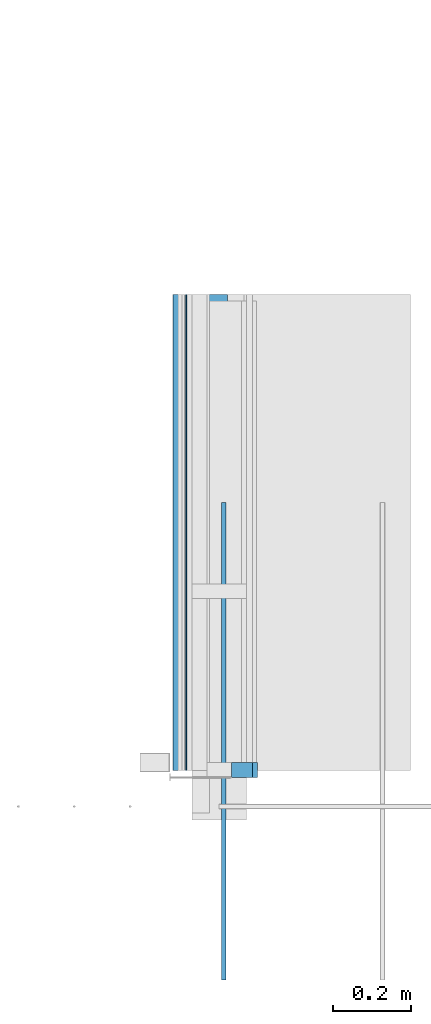
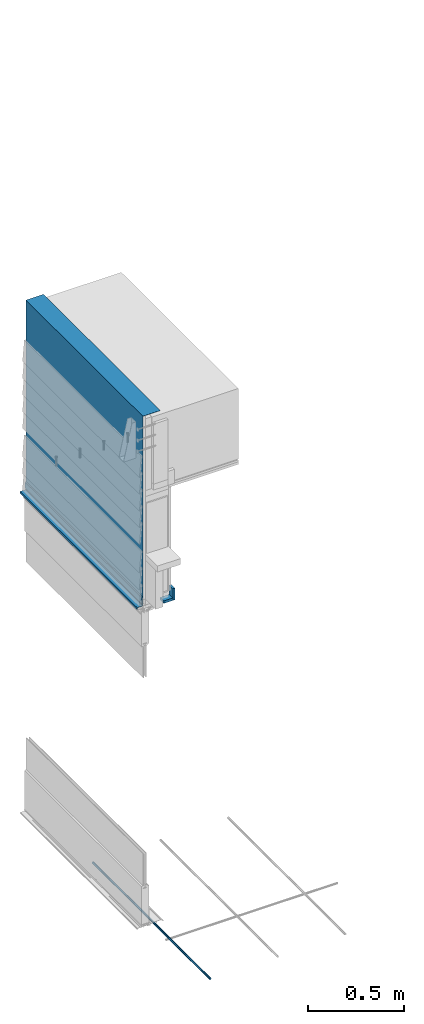
# One storey, part 3 of 44: 5 walls.
"""IFC4 building model written with IfcOpenShell, lengths in feet."""

import ifcopenshell
import ifcopenshell.guid

model = None  # the IFC model being written
_history = None  # IfcOwnerHistory: only IFC2X3 demands one
_inside = {}  # id of a spatial element -> (the spatial element, [elements in it])
_under = {}  # id of a project, library or spatial element -> (it, [spatial elements below it])
_declared = {}  # id of a project -> (the project, [libraries it declares])
_typed = {}  # id of a type object -> (the type object, [elements of that type])
_made_of = {}  # id of a material, layer set ... -> (it, [elements and type objects made of it])


def new_model(schema):
    """Start an empty IFC model of exactly this schema.

    Asked for "IFC4X3", IfcOpenShell would pick the latest addendum, in which some entities
    have other attributes; the version numbers below select the first issue.
    IFC2X3 requires an IfcOwnerHistory on every rooted entity: one is made here for all.
    """
    global model, _history
    if schema == "IFC4X3":
        model = ifcopenshell.file(schema_version=(4, 3, 0, 0))
    else:
        model = ifcopenshell.file(schema=schema)
    _inside.clear()
    _under.clear()
    _declared.clear()
    _typed.clear()
    _made_of.clear()
    _history = None
    if model.schema == "IFC2X3":
        org = make("IfcOrganization", Name="unknown")
        user = make(
            "IfcPersonAndOrganization",
            ThePerson=make("IfcPerson", FamilyName="unknown"),
            TheOrganization=org,
        )
        app = make(
            "IfcApplication",
            ApplicationDeveloper=org,
            Version="unknown",
            ApplicationFullName="unknown",
            ApplicationIdentifier="unknown",
        )
        _history = make(
            "IfcOwnerHistory",
            OwningUser=user,
            OwningApplication=app,
            ChangeAction="ADDED",
            CreationDate=0,
        )
    return model


def make(cls, **values):
    """One entity of the class cls with the attributes given. An attribute that is None is left unset."""
    return model.create_entity(
        cls, **{name: value for name, value in values.items() if value is not None}
    )


def entity(cls, *values):
    """Any entity or typed value of the class cls, its attributes in the order of the schema. None: left unset."""
    e = model.create_entity(cls)
    for i, value in enumerate(values):
        if value is not None:
            e[i] = value
    return e


def rooted(cls, **values):
    """An entity with a GlobalId (a new one), such as an element, a storey or a relation."""
    return make(cls, GlobalId=ifcopenshell.guid.new(), OwnerHistory=_history, **values)


def si_unit(unit_type, name, prefix=None):
    """IfcSIUnit, for example si_unit("LENGTHUNIT", "METRE", prefix="MILLI")."""
    return make("IfcSIUnit", UnitType=unit_type, Prefix=prefix, Name=name)


def converted_unit(unit_type, name, factor, base, dimensions=None, offset=None):
    """IfcConversionBasedUnit, such as the inch: factor (a typed value) times the base unit."""
    return make(
        "IfcConversionBasedUnit"
        if offset is None
        else "IfcConversionBasedUnitWithOffset",
        ConversionOffset=offset,
        Dimensions=None
        if dimensions is None
        else entity("IfcDimensionalExponents", *dimensions),
        UnitType=unit_type,
        Name=name,
        ConversionFactor=make(
            "IfcMeasureWithUnit", ValueComponent=factor, UnitComponent=base
        ),
    )


def derived_unit(unit_type, elements):
    """IfcDerivedUnit: a product of units, each with its exponent."""
    return make(
        "IfcDerivedUnit",
        Elements=[
            make("IfcDerivedUnitElement", Unit=unit, Exponent=power)
            for unit, power in elements
        ],
        UnitType=unit_type,
    )


def assignment(units):
    """IfcUnitAssignment: the units of a project."""
    return None if units is None else make("IfcUnitAssignment", Units=units)


def point(xyz):
    """IfcCartesianPoint."""
    return None if xyz is None else make("IfcCartesianPoint", Coordinates=xyz)


def direction(xyz):
    """IfcDirection."""
    return None if xyz is None else make("IfcDirection", DirectionRatios=xyz)


def frame(location, z_axis=None, x_axis=None):
    """IfcAxis2Placement3D, a coordinate frame: its origin and axes. An axis left out is left unset."""
    return make(
        "IfcAxis2Placement3D",
        Location=point(location),
        Axis=direction(z_axis),
        RefDirection=direction(x_axis),
    )


def frame_2d(location, x_axis=None):
    """IfcAxis2Placement2D, a coordinate frame in the plane: its origin and x axis."""
    return make(
        "IfcAxis2Placement2D", Location=point(location), RefDirection=direction(x_axis)
    )


def origin():
    """The frame at (0, 0, 0) with its axes left unset."""
    return frame((0.0, 0.0, 0.0))


def place(relative_to, where):
    """IfcLocalPlacement: puts the frame where relative to a parent placement (None: the world)."""
    return make(
        "IfcLocalPlacement", PlacementRelTo=relative_to, RelativePlacement=where
    )


def context(
    kind, dimensions, precision=None, world=None, true_north=None, identifier=None
):
    """IfcGeometricRepresentationContext, for example the 3D "Model" context."""
    return make(
        "IfcGeometricRepresentationContext",
        ContextIdentifier=identifier,
        ContextType=kind,
        CoordinateSpaceDimension=dimensions,
        Precision=precision,
        WorldCoordinateSystem=world,
        TrueNorth=true_north,
    )


def subcontext(parent, identifier, kind, view, scale=None):
    """IfcGeometricRepresentationSubContext, for example "Body" below "Model"."""
    return make(
        "IfcGeometricRepresentationSubContext",
        ContextIdentifier=identifier,
        ContextType=kind,
        ParentContext=parent,
        TargetScale=scale,
        TargetView=view,
    )


def project(units=None, contexts=None):
    """IfcProject with its units and contexts."""
    return rooted(
        "IfcProject",
        Name="project",
        RepresentationContexts=contexts,
        UnitsInContext=assignment(units),
    )


def spatial(cls, under=None, at=None, **own):
    """A site, building, storey or space (cls), placed at a placement, below another one or the project."""
    s = rooted(cls, ObjectPlacement=at, **own)
    if under is not None:
        _under.setdefault(under.id(), (under, []))[1].append(s)
    return s


def profile(cls, at=None, kind="AREA", **sizes):
    """A parametric profile (cls). Its sizes go by their IFC names, for example OverallWidth=200.0."""
    return make(cls, ProfileType=kind, Position=at, **sizes)


def rectangle(**sizes):
    """IfcRectangleProfileDef."""
    return profile("IfcRectangleProfileDef", **sizes)


def extrude(swept, where, along, depth):
    """IfcExtrudedAreaSolid: the profile swept, set in the frame where, extruded along a direction by depth."""
    return make(
        "IfcExtrudedAreaSolid",
        SweptArea=swept,
        Position=where,
        ExtrudedDirection=direction(along),
        Depth=depth,
    )


def shape(context_of_items, identifier, shape_type, items):
    """IfcShapeRepresentation: the items that make up one representation, for example the "Body"."""
    return make(
        "IfcShapeRepresentation",
        ContextOfItems=context_of_items,
        RepresentationIdentifier=identifier,
        RepresentationType=shape_type,
        Items=items,
    )


def material(Name=None, Category=None):
    """IfcMaterial."""
    return make("IfcMaterial", Name=Name, Category=Category)


def made_of(thing, what):
    """Note that an element or type object is made of a material, layer set ...; save() writes the relation."""
    if what is not None:
        _made_of.setdefault(what.id(), (what, []))[1].append(thing)
    return thing


def type_object(cls, material=None, **own):
    """A type object (cls), such as IfcWallType, which elements share."""
    return made_of(rooted(cls, **own), material)


def element(
    cls,
    number,
    at=None,
    inside=None,
    cuts=None,
    type_object=None,
    material=None,
    context=None,
    identifier="Body",
    shape_type=None,
    held_by="IfcProductDefinitionShape",
    body=None,
    shapes=None,
    **own,
):
    """One element of the class cls, such as IfcWall. Its Tag is "e" and its number.

    at: its placement. inside: the storey or other place that contains it. cuts: it is an
    opening in that element (IfcRelVoidsElement). A single representation is given by context,
    identifier, shape_type and body (its items); several are given by shapes. held_by: the class
    of the entity that holds the representations. save() writes the other relations.
    """
    e = rooted(cls, Tag="e%d" % number, ObjectPlacement=at, **own)
    if body is not None:
        shapes = [shape(context, identifier, shape_type, body)]
    if shapes is not None:
        e.Representation = make(held_by, Representations=shapes)
    if inside is not None:
        _inside.setdefault(inside.id(), (inside, []))[1].append(e)
    if cuts is not None:
        rooted(
            "IfcRelVoidsElement", RelatingBuildingElement=cuts, RelatedOpeningElement=e
        )
    if type_object is not None:
        _typed.setdefault(type_object.id(), (type_object, []))[1].append(e)
    return made_of(e, material)


def aggregate(whole, parts):
    """IfcRelAggregates: a whole, such as a stair, and the parts it consists of."""
    return rooted("IfcRelAggregates", RelatingObject=whole, RelatedObjects=parts)


def save(model, path):
    """Write the relations noted so far, then the file.

    IfcRelAggregates (storeys below a building ...), IfcRelContainedInSpatialStructure (elements
    in a storey), IfcRelDefinesByType, IfcRelAssociatesMaterial and IfcRelDeclares: one each for
    every whole, place, type object, material and project.
    """
    for whole, parts in _under.values():
        aggregate(whole, parts)
    for where, things in _inside.values():
        rooted(
            "IfcRelContainedInSpatialStructure",
            RelatedElements=things,
            RelatingStructure=where,
        )
    for kind, things in _typed.values():
        rooted("IfcRelDefinesByType", RelatedObjects=things, RelatingType=kind)
    for what, things in _made_of.values():
        rooted("IfcRelAssociatesMaterial", RelatedObjects=things, RelatingMaterial=what)
    for by, libraries in _declared.values():
        rooted("IfcRelDeclares", RelatingContext=by, RelatedDefinitions=libraries)
    model.write(path)


model = new_model("IFC4")

# Units and contexts
model_context = context("Model", 3, precision=0.0001, world=origin(), true_north=direction((6.12303176911189e-17, 1.0)))
body_context = subcontext(model_context, "Body", "Model", "MODEL_VIEW")
ifc_project = project(units=[converted_unit("LENGTHUNIT", "FOOT", entity("IfcRatioMeasure", 0.3048), si_unit("LENGTHUNIT", "METRE"), dimensions=[1, 0, 0, 0, 0, 0, 0]), converted_unit("AREAUNIT", "SQUARE FOOT", entity("IfcRatioMeasure", 0.09290304), si_unit("AREAUNIT", "SQUARE_METRE"), dimensions=[2, 0, 0, 0, 0, 0, 0]), converted_unit("VOLUMEUNIT", "CUBIC FOOT", entity("IfcRatioMeasure", 0.028316846592), si_unit("VOLUMEUNIT", "CUBIC_METRE"), dimensions=[3, 0, 0, 0, 0, 0, 0]), converted_unit("PLANEANGLEUNIT", "DEGREE", entity("IfcRatioMeasure", 0.0174532925199433), si_unit("PLANEANGLEUNIT", "RADIAN"), dimensions=[0, 0, 0, 0, 0, 0, 0]), si_unit("MASSUNIT", "GRAM", prefix="KILO"), derived_unit("MASSDENSITYUNIT", [(si_unit("MASSUNIT", "GRAM", prefix="KILO"), 1), (si_unit("LENGTHUNIT", "METRE"), -3)]), derived_unit("MOMENTOFINERTIAUNIT", [(si_unit("LENGTHUNIT", "METRE"), 4)]), si_unit("TIMEUNIT", "SECOND"), si_unit("FREQUENCYUNIT", "HERTZ"), si_unit("THERMODYNAMICTEMPERATUREUNIT", "DEGREE_CELSIUS"), derived_unit("THERMALTRANSMITTANCEUNIT", [(si_unit("MASSUNIT", "GRAM", prefix="KILO"), 1), (si_unit("THERMODYNAMICTEMPERATUREUNIT", "KELVIN"), -1), (si_unit("TIMEUNIT", "SECOND"), -3)]), derived_unit("VOLUMETRICFLOWRATEUNIT", [(si_unit("LENGTHUNIT", "METRE"), 3), (si_unit("TIMEUNIT", "SECOND"), -1)]), si_unit("ELECTRICCURRENTUNIT", "AMPERE"), si_unit("ELECTRICVOLTAGEUNIT", "VOLT"), si_unit("POWERUNIT", "WATT"), si_unit("FORCEUNIT", "NEWTON"), si_unit("ILLUMINANCEUNIT", "LUX"), si_unit("LUMINOUSFLUXUNIT", "LUMEN"), si_unit("LUMINOUSINTENSITYUNIT", "CANDELA"), derived_unit("USERDEFINED", [(si_unit("MASSUNIT", "GRAM", prefix="KILO"), -1), (si_unit("LENGTHUNIT", "METRE"), -2), (si_unit("TIMEUNIT", "SECOND"), 3), (si_unit("LUMINOUSFLUXUNIT", "LUMEN"), 1)]), derived_unit("LINEARVELOCITYUNIT", [(si_unit("LENGTHUNIT", "METRE"), 1), (si_unit("TIMEUNIT", "SECOND"), -1)]), si_unit("PRESSUREUNIT", "PASCAL"), derived_unit("USERDEFINED", [(si_unit("LENGTHUNIT", "METRE"), -2), (si_unit("MASSUNIT", "GRAM", prefix="KILO"), 1), (si_unit("TIMEUNIT", "SECOND"), -2)]), derived_unit("LINEARFORCEUNIT", [(si_unit("MASSUNIT", "GRAM", prefix="KILO"), 1), (si_unit("LENGTHUNIT", "METRE"), 1), (si_unit("TIMEUNIT", "SECOND"), -2), (si_unit("LENGTHUNIT", "METRE"), -1)]), derived_unit("PLANARFORCEUNIT", [(si_unit("MASSUNIT", "GRAM", prefix="KILO"), 1), (si_unit("LENGTHUNIT", "METRE"), 1), (si_unit("TIMEUNIT", "SECOND"), -2), (si_unit("LENGTHUNIT", "METRE"), -2)])], contexts=[model_context])

# Site, building, storey
site_placement = place(None, origin())
site = spatial("IfcSite", under=ifc_project, at=site_placement, CompositionType="ELEMENT")
building_placement = place(site_placement, origin())
building = spatial("IfcBuilding", under=site, at=building_placement, CompositionType="ELEMENT")
storey_placement = place(building_placement, origin())
storey = spatial("IfcBuildingStorey", under=building, at=storey_placement, CompositionType="ELEMENT", Elevation=0.0)

# Walls
ifc_material_1 = material(Name="JAMB EXTENSION", Category="Materials")
wall_type_1 = type_object("IfcWallType", Name="Generic Models 633:Generic Models 1", PredefinedType="NOTDEFINED", material=ifc_material_1)
wall_1_placement = place(storey_placement, frame((1459.64300191324, 1.94270833332938, 6.66666666666672)))
element("IfcWall", 1, at=wall_1_placement, inside=storey, type_object=wall_type_1, material=ifc_material_1, Name="Generic Models 633:Generic Models 1", ObjectType="Generic Models 633:Generic Models 1", PredefinedType="NOTDEFINED", context=body_context, shape_type="SweptSolid", body=[
    extrude(rectangle(XDim=0.125000000000002, YDim=0.178223473905518, at=frame_2d((0.0, 1.13686837721616e-13), x_axis=(1.0, 0.0))), frame((0.0891117369528729, 0.0625000000000013, 0.0), z_axis=(0.0, 0.0, 1.0), x_axis=(0.0, 1.0, 0.0)), (0.0, 0.0, 1.0), 0.0521184984729377),
])
wall_type_2 = type_object("IfcWallType", Name="Generic Models 634:Generic Models 1", PredefinedType="NOTDEFINED", material=ifc_material_1)
wall_2_placement = place(storey_placement, frame((1459.82122538715, 1.94270833332938, 6.66666666666673), z_axis=(0.0, 0.0, 1.0), x_axis=(0.0, 1.0, 0.0)))
element("IfcWall", 2, at=wall_2_placement, inside=storey, type_object=wall_type_2, material=ifc_material_1, Name="Generic Models 634:Generic Models 1", ObjectType="Generic Models 634:Generic Models 1", PredefinedType="NOTDEFINED", context=body_context, shape_type="SweptSolid", body=[
    extrude(rectangle(XDim=0.125000000000001, YDim=0.0423333333333176, at=frame_2d((2.22044604925031e-16, 0.0), x_axis=(1.0, 0.0))), frame((0.0625000000000007, -0.0211666666666588, 0.0)), (0.0, 0.0, 1.0), 0.245234928007256),
])
ifc_material_2 = material(Name="DRAINAGE WRAP - ASTM 2273", Category="Materials")
wall_type_3 = type_object("IfcWallType", Name="Generic Models 656:Generic Models 1", PredefinedType="NOTDEFINED", material=ifc_material_2)
wall_3_placement = place(storey_placement, frame((1459.25135878288, 2.0, 6.75024837108032), z_axis=(0.0, 0.0, 1.0), x_axis=(0.0, 1.0, 0.0)))
cartesian_point_1 = entity("IfcCartesianPoint", [4.0, -0.013046868956053, 3.92149702920678])
vertex_point_1 = entity("IfcVertexPoint", cartesian_point_1)
cartesian_point_2 = entity("IfcCartesianPoint", [4.0, -0.360024214241321, 3.92149702920678])
vertex_point_2 = entity("IfcVertexPoint", cartesian_point_2)
ifc_direction_1 = entity("IfcDirection", [0.0, -1.0, 0.0])
edge_curve_1 = entity("IfcEdgeCurve", vertex_point_1, vertex_point_2, entity("IfcTrimmedCurve", entity("IfcLine", cartesian_point_1, entity("IfcVector", ifc_direction_1, 1.0)), [cartesian_point_1], [cartesian_point_2], True, "CARTESIAN"), True)
cartesian_point_3 = entity("IfcCartesianPoint", [4.0, -0.360024214241321, 3.91824182087345])
vertex_point_3 = entity("IfcVertexPoint", cartesian_point_3)
ifc_direction_2 = entity("IfcDirection", [0.0, 0.0, -1.0])
edge_curve_2 = entity("IfcEdgeCurve", vertex_point_2, vertex_point_3, entity("IfcTrimmedCurve", entity("IfcLine", cartesian_point_2, entity("IfcVector", ifc_direction_2, 1.0)), [cartesian_point_2], [cartesian_point_3], True, "CARTESIAN"), True)
cartesian_point_4 = entity("IfcCartesianPoint", [4.0, -0.0163802022893833, 3.91824182087345])
vertex_point_4 = entity("IfcVertexPoint", cartesian_point_4)
ifc_direction_3 = entity("IfcDirection", [0.0, 1.0, 0.0])
edge_curve_3 = entity("IfcEdgeCurve", vertex_point_3, vertex_point_4, entity("IfcTrimmedCurve", entity("IfcLine", cartesian_point_3, entity("IfcVector", ifc_direction_3, 1.0)), [cartesian_point_3], [cartesian_point_4], True, "CARTESIAN"), True)
cartesian_point_5 = entity("IfcCartesianPoint", [4.0, -0.0163802022893833, 0.145405747467168])
vertex_point_5 = entity("IfcVertexPoint", cartesian_point_5)
edge_curve_4 = entity("IfcEdgeCurve", vertex_point_4, vertex_point_5, entity("IfcTrimmedCurve", entity("IfcLine", cartesian_point_4, entity("IfcVector", ifc_direction_2, 1.0)), [cartesian_point_4], [cartesian_point_5], True, "CARTESIAN"), True)
cartesian_point_6 = entity("IfcCartesianPoint", [4.0, -0.0033333333333303, 0.122807907555591])
vertex_point_6 = entity("IfcVertexPoint", cartesian_point_6)
edge_curve_5 = entity("IfcEdgeCurve", vertex_point_5, vertex_point_6, entity("IfcTrimmedCurve", entity("IfcLine", cartesian_point_5, entity("IfcVector", entity("IfcDirection", [0.0, 0.5, -0.866025403784439]), 1.0)), [cartesian_point_5], [cartesian_point_6], True, "CARTESIAN"), True)
cartesian_point_7 = entity("IfcCartesianPoint", [4.0, -0.0033333333333303, 0.0])
vertex_point_7 = entity("IfcVertexPoint", cartesian_point_7)
edge_curve_6 = entity("IfcEdgeCurve", vertex_point_6, vertex_point_7, entity("IfcTrimmedCurve", entity("IfcLine", cartesian_point_6, entity("IfcVector", ifc_direction_2, 1.0)), [cartesian_point_6], [cartesian_point_7], True, "CARTESIAN"), True)
cartesian_point_8 = entity("IfcCartesianPoint", [4.0, 0.0, 0.0])
vertex_point_8 = entity("IfcVertexPoint", cartesian_point_8)
edge_curve_7 = entity("IfcEdgeCurve", vertex_point_7, vertex_point_8, entity("IfcTrimmedCurve", entity("IfcLine", cartesian_point_7, entity("IfcVector", ifc_direction_3, 1.0)), [cartesian_point_7], [cartesian_point_8], True, "CARTESIAN"), True)
cartesian_point_9 = entity("IfcCartesianPoint", [4.0, 0.0, 0.12415446033406])
vertex_point_9 = entity("IfcVertexPoint", cartesian_point_9)
ifc_direction_4 = entity("IfcDirection", [0.0, 0.0, 1.0])
edge_curve_8 = entity("IfcEdgeCurve", vertex_point_8, vertex_point_9, entity("IfcTrimmedCurve", entity("IfcLine", cartesian_point_8, entity("IfcVector", ifc_direction_4, 1.0)), [cartesian_point_8], [cartesian_point_9], True, "CARTESIAN"), True)
cartesian_point_10 = entity("IfcCartesianPoint", [4.0, -0.013046868956053, 0.146752300245637])
vertex_point_10 = entity("IfcVertexPoint", cartesian_point_10)
edge_curve_9 = entity("IfcEdgeCurve", vertex_point_9, vertex_point_10, entity("IfcTrimmedCurve", entity("IfcLine", cartesian_point_9, entity("IfcVector", entity("IfcDirection", [0.0, -0.5, 0.866025403784439]), 1.0)), [cartesian_point_9], [cartesian_point_10], True, "CARTESIAN"), True)
edge_curve_10 = entity("IfcEdgeCurve", vertex_point_10, vertex_point_1, entity("IfcTrimmedCurve", entity("IfcLine", cartesian_point_10, entity("IfcVector", ifc_direction_4, 1.0)), [cartesian_point_10], [cartesian_point_1], True, "CARTESIAN"), True)
ifc_direction_5 = entity("IfcDirection", [1.0, 0.0, 0.0])
cartesian_point_11 = entity("IfcCartesianPoint", [0.0, -0.013046868956053, 3.92149702920679])
vertex_point_11 = entity("IfcVertexPoint", cartesian_point_11)
cartesian_point_12 = entity("IfcCartesianPoint", [0.0, -0.013046868956053, 0.146752300245644])
vertex_point_12 = entity("IfcVertexPoint", cartesian_point_12)
edge_curve_11 = entity("IfcEdgeCurve", vertex_point_11, vertex_point_12, entity("IfcTrimmedCurve", entity("IfcLine", cartesian_point_11, entity("IfcVector", ifc_direction_2, 1.0)), [cartesian_point_11], [cartesian_point_12], True, "CARTESIAN"), True)
cartesian_point_13 = entity("IfcCartesianPoint", [0.0, 0.0, 0.124154460334067])
vertex_point_13 = entity("IfcVertexPoint", cartesian_point_13)
edge_curve_12 = entity("IfcEdgeCurve", vertex_point_12, vertex_point_13, entity("IfcTrimmedCurve", entity("IfcLine", cartesian_point_12, entity("IfcVector", entity("IfcDirection", [0.0, 0.5, -0.866025403784439]), 1.0)), [cartesian_point_12], [cartesian_point_13], True, "CARTESIAN"), True)
cartesian_point_14 = entity("IfcCartesianPoint", [0.0, 0.0, 0.0])
vertex_point_14 = entity("IfcVertexPoint", cartesian_point_14)
edge_curve_13 = entity("IfcEdgeCurve", vertex_point_13, vertex_point_14, entity("IfcTrimmedCurve", entity("IfcLine", cartesian_point_13, entity("IfcVector", ifc_direction_2, 1.0)), [cartesian_point_13], [cartesian_point_14], True, "CARTESIAN"), True)
cartesian_point_15 = entity("IfcCartesianPoint", [0.0, -0.0033333333333303, 0.0])
vertex_point_15 = entity("IfcVertexPoint", cartesian_point_15)
edge_curve_14 = entity("IfcEdgeCurve", vertex_point_14, vertex_point_15, entity("IfcTrimmedCurve", entity("IfcLine", cartesian_point_14, entity("IfcVector", ifc_direction_1, 1.0)), [cartesian_point_14], [cartesian_point_15], True, "CARTESIAN"), True)
cartesian_point_16 = entity("IfcCartesianPoint", [0.0, -0.0033333333333303, 0.122807907555598])
vertex_point_16 = entity("IfcVertexPoint", cartesian_point_16)
edge_curve_15 = entity("IfcEdgeCurve", vertex_point_15, vertex_point_16, entity("IfcTrimmedCurve", entity("IfcLine", cartesian_point_15, entity("IfcVector", ifc_direction_4, 1.0)), [cartesian_point_15], [cartesian_point_16], True, "CARTESIAN"), True)
cartesian_point_17 = entity("IfcCartesianPoint", [0.0, -0.0163802022893833, 0.145405747467175])
vertex_point_17 = entity("IfcVertexPoint", cartesian_point_17)
edge_curve_16 = entity("IfcEdgeCurve", vertex_point_16, vertex_point_17, entity("IfcTrimmedCurve", entity("IfcLine", cartesian_point_16, entity("IfcVector", entity("IfcDirection", [0.0, -0.5, 0.866025403784439]), 1.0)), [cartesian_point_16], [cartesian_point_17], True, "CARTESIAN"), True)
cartesian_point_18 = entity("IfcCartesianPoint", [0.0, -0.0163802022893833, 3.91824182087345])
vertex_point_18 = entity("IfcVertexPoint", cartesian_point_18)
edge_curve_17 = entity("IfcEdgeCurve", vertex_point_17, vertex_point_18, entity("IfcTrimmedCurve", entity("IfcLine", cartesian_point_17, entity("IfcVector", ifc_direction_4, 1.0)), [cartesian_point_17], [cartesian_point_18], True, "CARTESIAN"), True)
cartesian_point_19 = entity("IfcCartesianPoint", [0.0, -0.360024214241321, 3.91824182087345])
vertex_point_19 = entity("IfcVertexPoint", cartesian_point_19)
edge_curve_18 = entity("IfcEdgeCurve", vertex_point_18, vertex_point_19, entity("IfcTrimmedCurve", entity("IfcLine", cartesian_point_18, entity("IfcVector", ifc_direction_1, 1.0)), [cartesian_point_18], [cartesian_point_19], True, "CARTESIAN"), True)
cartesian_point_20 = entity("IfcCartesianPoint", [0.0, -0.360024214241321, 3.92149702920679])
vertex_point_20 = entity("IfcVertexPoint", cartesian_point_20)
edge_curve_19 = entity("IfcEdgeCurve", vertex_point_19, vertex_point_20, entity("IfcTrimmedCurve", entity("IfcLine", cartesian_point_19, entity("IfcVector", ifc_direction_4, 1.0)), [cartesian_point_19], [cartesian_point_20], True, "CARTESIAN"), True)
edge_curve_20 = entity("IfcEdgeCurve", vertex_point_20, vertex_point_11, entity("IfcTrimmedCurve", entity("IfcLine", cartesian_point_20, entity("IfcVector", ifc_direction_3, 1.0)), [cartesian_point_20], [cartesian_point_11], True, "CARTESIAN"), True)
ifc_direction_6 = entity("IfcDirection", [-1.0, 0.0, 0.0])
edge_curve_21 = entity("IfcEdgeCurve", vertex_point_17, vertex_point_5, entity("IfcTrimmedCurve", entity("IfcLine", cartesian_point_17, entity("IfcVector", ifc_direction_5, 1.0)), [cartesian_point_17], [cartesian_point_5], True, "CARTESIAN"), True)
edge_curve_22 = entity("IfcEdgeCurve", vertex_point_4, vertex_point_18, entity("IfcTrimmedCurve", entity("IfcLine", cartesian_point_18, entity("IfcVector", ifc_direction_6, 1.0)), [cartesian_point_4], [cartesian_point_18], True, "CARTESIAN"), True)
edge_curve_23 = entity("IfcEdgeCurve", vertex_point_11, vertex_point_1, entity("IfcTrimmedCurve", entity("IfcLine", cartesian_point_11, entity("IfcVector", ifc_direction_5, 1.0)), [cartesian_point_11], [cartesian_point_1], True, "CARTESIAN"), True)
edge_curve_24 = entity("IfcEdgeCurve", vertex_point_10, vertex_point_12, entity("IfcTrimmedCurve", entity("IfcLine", cartesian_point_12, entity("IfcVector", ifc_direction_6, 1.0)), [cartesian_point_10], [cartesian_point_12], True, "CARTESIAN"), True)
edge_curve_25 = entity("IfcEdgeCurve", vertex_point_3, vertex_point_19, entity("IfcTrimmedCurve", entity("IfcLine", cartesian_point_19, entity("IfcVector", ifc_direction_6, 1.0)), [cartesian_point_3], [cartesian_point_19], True, "CARTESIAN"), True)
edge_curve_26 = entity("IfcEdgeCurve", vertex_point_2, vertex_point_20, entity("IfcTrimmedCurve", entity("IfcLine", cartesian_point_20, entity("IfcVector", ifc_direction_6, 1.0)), [cartesian_point_2], [cartesian_point_20], True, "CARTESIAN"), True)
edge_curve_27 = entity("IfcEdgeCurve", vertex_point_9, vertex_point_13, entity("IfcTrimmedCurve", entity("IfcLine", cartesian_point_13, entity("IfcVector", ifc_direction_6, 1.0)), [cartesian_point_9], [cartesian_point_13], True, "CARTESIAN"), True)
edge_curve_28 = entity("IfcEdgeCurve", vertex_point_8, vertex_point_14, entity("IfcTrimmedCurve", entity("IfcLine", cartesian_point_14, entity("IfcVector", ifc_direction_6, 1.0)), [cartesian_point_8], [cartesian_point_14], True, "CARTESIAN"), True)
edge_curve_29 = entity("IfcEdgeCurve", vertex_point_7, vertex_point_15, entity("IfcTrimmedCurve", entity("IfcLine", cartesian_point_15, entity("IfcVector", ifc_direction_6, 1.0)), [cartesian_point_7], [cartesian_point_15], True, "CARTESIAN"), True)
edge_curve_30 = entity("IfcEdgeCurve", vertex_point_6, vertex_point_16, entity("IfcTrimmedCurve", entity("IfcLine", cartesian_point_16, entity("IfcVector", ifc_direction_6, 1.0)), [cartesian_point_6], [cartesian_point_16], True, "CARTESIAN"), True)
element("IfcWall", 3, at=wall_3_placement, inside=storey, type_object=wall_type_3, material=ifc_material_2, Name="Generic Models 656:Generic Models 1", ObjectType="Generic Models 656:Generic Models 1", PredefinedType="NOTDEFINED", context=body_context, shape_type="AdvancedBrep", body=[
    entity("IfcAdvancedBrep", entity("IfcClosedShell", [entity("IfcAdvancedFace", [entity("IfcFaceOuterBound", entity("IfcEdgeLoop", [entity("IfcOrientedEdge", None, None, edge_curve_1, True), entity("IfcOrientedEdge", None, None, edge_curve_2, True), entity("IfcOrientedEdge", None, None, edge_curve_3, True), entity("IfcOrientedEdge", None, None, edge_curve_4, True), entity("IfcOrientedEdge", None, None, edge_curve_5, True), entity("IfcOrientedEdge", None, None, edge_curve_6, True), entity("IfcOrientedEdge", None, None, edge_curve_7, True), entity("IfcOrientedEdge", None, None, edge_curve_8, True), entity("IfcOrientedEdge", None, None, edge_curve_9, True), entity("IfcOrientedEdge", None, None, edge_curve_10, True)]), True)], entity("IfcPlane", entity("IfcAxis2Placement3D", entity("IfcCartesianPoint", [4.0, -0.013046868956053, -6.12342484579256]), ifc_direction_5, ifc_direction_4)), True), entity("IfcAdvancedFace", [entity("IfcFaceOuterBound", entity("IfcEdgeLoop", [entity("IfcOrientedEdge", None, None, edge_curve_11, True), entity("IfcOrientedEdge", None, None, edge_curve_12, True), entity("IfcOrientedEdge", None, None, edge_curve_13, True), entity("IfcOrientedEdge", None, None, edge_curve_14, True), entity("IfcOrientedEdge", None, None, edge_curve_15, True), entity("IfcOrientedEdge", None, None, edge_curve_16, True), entity("IfcOrientedEdge", None, None, edge_curve_17, True), entity("IfcOrientedEdge", None, None, edge_curve_18, True), entity("IfcOrientedEdge", None, None, edge_curve_19, True), entity("IfcOrientedEdge", None, None, edge_curve_20, True)]), True)], entity("IfcPlane", entity("IfcAxis2Placement3D", entity("IfcCartesianPoint", [0.0, -0.013046868956053, -6.12342484579256]), ifc_direction_6, ifc_direction_2)), True), entity("IfcAdvancedFace", [entity("IfcFaceOuterBound", entity("IfcEdgeLoop", [entity("IfcOrientedEdge", None, None, edge_curve_17, False), entity("IfcOrientedEdge", None, None, edge_curve_21, True), entity("IfcOrientedEdge", None, None, edge_curve_4, False), entity("IfcOrientedEdge", None, None, edge_curve_22, True)]), True)], entity("IfcPlane", entity("IfcAxis2Placement3D", cartesian_point_17, ifc_direction_1, ifc_direction_5)), True), entity("IfcAdvancedFace", [entity("IfcFaceOuterBound", entity("IfcEdgeLoop", [entity("IfcOrientedEdge", None, None, edge_curve_11, False), entity("IfcOrientedEdge", None, None, edge_curve_23, True), entity("IfcOrientedEdge", None, None, edge_curve_10, False), entity("IfcOrientedEdge", None, None, edge_curve_24, True)]), True)], entity("IfcPlane", entity("IfcAxis2Placement3D", cartesian_point_11, ifc_direction_3, ifc_direction_5)), True), entity("IfcAdvancedFace", [entity("IfcFaceOuterBound", entity("IfcEdgeLoop", [entity("IfcOrientedEdge", None, None, edge_curve_18, False), entity("IfcOrientedEdge", None, None, edge_curve_22, False), entity("IfcOrientedEdge", None, None, edge_curve_3, False), entity("IfcOrientedEdge", None, None, edge_curve_25, True)]), True)], entity("IfcPlane", entity("IfcAxis2Placement3D", cartesian_point_18, ifc_direction_2, ifc_direction_5)), True), entity("IfcAdvancedFace", [entity("IfcFaceOuterBound", entity("IfcEdgeLoop", [entity("IfcOrientedEdge", None, None, edge_curve_19, False), entity("IfcOrientedEdge", None, None, edge_curve_25, False), entity("IfcOrientedEdge", None, None, edge_curve_2, False), entity("IfcOrientedEdge", None, None, edge_curve_26, True)]), True)], entity("IfcPlane", entity("IfcAxis2Placement3D", cartesian_point_19, ifc_direction_1, ifc_direction_5)), True), entity("IfcAdvancedFace", [entity("IfcFaceOuterBound", entity("IfcEdgeLoop", [entity("IfcOrientedEdge", None, None, edge_curve_20, False), entity("IfcOrientedEdge", None, None, edge_curve_26, False), entity("IfcOrientedEdge", None, None, edge_curve_1, False), entity("IfcOrientedEdge", None, None, edge_curve_23, False)]), True)], entity("IfcPlane", entity("IfcAxis2Placement3D", cartesian_point_20, ifc_direction_4, ifc_direction_5)), True), entity("IfcAdvancedFace", [entity("IfcFaceOuterBound", entity("IfcEdgeLoop", [entity("IfcOrientedEdge", None, None, edge_curve_12, False), entity("IfcOrientedEdge", None, None, edge_curve_24, False), entity("IfcOrientedEdge", None, None, edge_curve_9, False), entity("IfcOrientedEdge", None, None, edge_curve_27, True)]), True)], entity("IfcPlane", entity("IfcAxis2Placement3D", cartesian_point_12, entity("IfcDirection", [0.0, 0.866025403784439, 0.5]), ifc_direction_5)), True), entity("IfcAdvancedFace", [entity("IfcFaceOuterBound", entity("IfcEdgeLoop", [entity("IfcOrientedEdge", None, None, edge_curve_13, False), entity("IfcOrientedEdge", None, None, edge_curve_27, False), entity("IfcOrientedEdge", None, None, edge_curve_8, False), entity("IfcOrientedEdge", None, None, edge_curve_28, True)]), True)], entity("IfcPlane", entity("IfcAxis2Placement3D", cartesian_point_13, ifc_direction_3, ifc_direction_5)), True), entity("IfcAdvancedFace", [entity("IfcFaceOuterBound", entity("IfcEdgeLoop", [entity("IfcOrientedEdge", None, None, edge_curve_14, False), entity("IfcOrientedEdge", None, None, edge_curve_28, False), entity("IfcOrientedEdge", None, None, edge_curve_7, False), entity("IfcOrientedEdge", None, None, edge_curve_29, True)]), True)], entity("IfcPlane", entity("IfcAxis2Placement3D", cartesian_point_14, ifc_direction_2, ifc_direction_5)), True), entity("IfcAdvancedFace", [entity("IfcFaceOuterBound", entity("IfcEdgeLoop", [entity("IfcOrientedEdge", None, None, edge_curve_15, False), entity("IfcOrientedEdge", None, None, edge_curve_29, False), entity("IfcOrientedEdge", None, None, edge_curve_6, False), entity("IfcOrientedEdge", None, None, edge_curve_30, True)]), True)], entity("IfcPlane", entity("IfcAxis2Placement3D", cartesian_point_15, ifc_direction_1, ifc_direction_5)), True), entity("IfcAdvancedFace", [entity("IfcFaceOuterBound", entity("IfcEdgeLoop", [entity("IfcOrientedEdge", None, None, edge_curve_16, False), entity("IfcOrientedEdge", None, None, edge_curve_30, False), entity("IfcOrientedEdge", None, None, edge_curve_5, False), entity("IfcOrientedEdge", None, None, edge_curve_21, False)]), True)], entity("IfcPlane", entity("IfcAxis2Placement3D", cartesian_point_16, entity("IfcDirection", [0.0, -0.866025403784439, -0.5]), ifc_direction_5)), True)])),
])
ifc_material_3 = material(Name="METAL FLASHING", Category="Materials")
wall_type_4 = type_object("IfcWallType", Name="Generic Models 674:Generic Models 1", PredefinedType="NOTDEFINED", material=ifc_material_3)
wall_4_placement = place(storey_placement, frame((1459.15117208794, 2.0, 6.67500537856836), z_axis=(0.0, 0.0, 1.0), x_axis=(0.0, 1.0, 0.0)))
cartesian_point_21 = entity("IfcCartesianPoint", [4.0, -0.105887183956611, 0.171849896106434])
vertex_point_21 = entity("IfcVertexPoint", cartesian_point_21)
cartesian_point_22 = entity("IfcCartesianPoint", [4.0, -0.109220517289941, 0.171849896106434])
vertex_point_22 = entity("IfcVertexPoint", cartesian_point_22)
ifc_direction_7 = entity("IfcDirection", [0.0, -1.0, 0.0])
edge_curve_31 = entity("IfcEdgeCurve", vertex_point_21, vertex_point_22, entity("IfcTrimmedCurve", entity("IfcLine", cartesian_point_21, entity("IfcVector", ifc_direction_7, 1.0)), [cartesian_point_21], [cartesian_point_22], True, "CARTESIAN"), True)
cartesian_point_23 = entity("IfcCartesianPoint", [4.0, -0.109220517289941, 0.0403333333332467])
vertex_point_23 = entity("IfcVertexPoint", cartesian_point_23)
ifc_direction_8 = entity("IfcDirection", [0.0, 0.0, -1.0])
edge_curve_32 = entity("IfcEdgeCurve", vertex_point_22, vertex_point_23, entity("IfcTrimmedCurve", entity("IfcLine", cartesian_point_22, entity("IfcVector", ifc_direction_8, 1.0)), [cartesian_point_22], [cartesian_point_23], True, "CARTESIAN"), True)
cartesian_point_24 = entity("IfcCartesianPoint", [4.0, -0.0033333333333303, 0.0403333333332467])
vertex_point_24 = entity("IfcVertexPoint", cartesian_point_24)
ifc_direction_9 = entity("IfcDirection", [0.0, 1.0, 0.0])
edge_curve_33 = entity("IfcEdgeCurve", vertex_point_23, vertex_point_24, entity("IfcTrimmedCurve", entity("IfcLine", cartesian_point_23, entity("IfcVector", ifc_direction_9, 1.0)), [cartesian_point_23], [cartesian_point_24], True, "CARTESIAN"), True)
cartesian_point_25 = entity("IfcCartesianPoint", [4.0, -0.0033333333333303, 0.0])
vertex_point_25 = entity("IfcVertexPoint", cartesian_point_25)
edge_curve_34 = entity("IfcEdgeCurve", vertex_point_24, vertex_point_25, entity("IfcTrimmedCurve", entity("IfcLine", cartesian_point_24, entity("IfcVector", ifc_direction_8, 1.0)), [cartesian_point_24], [cartesian_point_25], True, "CARTESIAN"), True)
cartesian_point_26 = entity("IfcCartesianPoint", [4.0, 0.0, 0.0])
vertex_point_26 = entity("IfcVertexPoint", cartesian_point_26)
edge_curve_35 = entity("IfcEdgeCurve", vertex_point_25, vertex_point_26, entity("IfcTrimmedCurve", entity("IfcLine", cartesian_point_25, entity("IfcVector", ifc_direction_9, 1.0)), [cartesian_point_25], [cartesian_point_26], True, "CARTESIAN"), True)
cartesian_point_27 = entity("IfcCartesianPoint", [4.0, 0.0, 0.0435885416665798])
vertex_point_27 = entity("IfcVertexPoint", cartesian_point_27)
ifc_direction_10 = entity("IfcDirection", [0.0, 0.0, 1.0])
edge_curve_36 = entity("IfcEdgeCurve", vertex_point_26, vertex_point_27, entity("IfcTrimmedCurve", entity("IfcLine", cartesian_point_26, entity("IfcVector", ifc_direction_10, 1.0)), [cartesian_point_26], [cartesian_point_27], True, "CARTESIAN"), True)
cartesian_point_28 = entity("IfcCartesianPoint", [4.0, -0.105887183956611, 0.0435885416665798])
vertex_point_28 = entity("IfcVertexPoint", cartesian_point_28)
edge_curve_37 = entity("IfcEdgeCurve", vertex_point_27, vertex_point_28, entity("IfcTrimmedCurve", entity("IfcLine", cartesian_point_27, entity("IfcVector", ifc_direction_7, 1.0)), [cartesian_point_27], [cartesian_point_28], True, "CARTESIAN"), True)
edge_curve_38 = entity("IfcEdgeCurve", vertex_point_28, vertex_point_21, entity("IfcTrimmedCurve", entity("IfcLine", cartesian_point_28, entity("IfcVector", ifc_direction_10, 1.0)), [cartesian_point_28], [cartesian_point_21], True, "CARTESIAN"), True)
ifc_direction_11 = entity("IfcDirection", [1.0, 0.0, 0.0])
cartesian_point_29 = entity("IfcCartesianPoint", [0.0, -0.105887183956611, 0.171849896106441])
vertex_point_29 = entity("IfcVertexPoint", cartesian_point_29)
cartesian_point_30 = entity("IfcCartesianPoint", [0.0, -0.105887183956611, 0.0435885416665869])
vertex_point_30 = entity("IfcVertexPoint", cartesian_point_30)
edge_curve_39 = entity("IfcEdgeCurve", vertex_point_29, vertex_point_30, entity("IfcTrimmedCurve", entity("IfcLine", cartesian_point_29, entity("IfcVector", ifc_direction_8, 1.0)), [cartesian_point_29], [cartesian_point_30], True, "CARTESIAN"), True)
cartesian_point_31 = entity("IfcCartesianPoint", [0.0, 0.0, 0.0435885416665869])
vertex_point_31 = entity("IfcVertexPoint", cartesian_point_31)
edge_curve_40 = entity("IfcEdgeCurve", vertex_point_30, vertex_point_31, entity("IfcTrimmedCurve", entity("IfcLine", cartesian_point_30, entity("IfcVector", ifc_direction_9, 1.0)), [cartesian_point_30], [cartesian_point_31], True, "CARTESIAN"), True)
cartesian_point_32 = entity("IfcCartesianPoint", [0.0, 0.0, 0.0])
vertex_point_32 = entity("IfcVertexPoint", cartesian_point_32)
edge_curve_41 = entity("IfcEdgeCurve", vertex_point_31, vertex_point_32, entity("IfcTrimmedCurve", entity("IfcLine", cartesian_point_31, entity("IfcVector", ifc_direction_8, 1.0)), [cartesian_point_31], [cartesian_point_32], True, "CARTESIAN"), True)
cartesian_point_33 = entity("IfcCartesianPoint", [0.0, -0.0033333333333303, 0.0])
vertex_point_33 = entity("IfcVertexPoint", cartesian_point_33)
edge_curve_42 = entity("IfcEdgeCurve", vertex_point_32, vertex_point_33, entity("IfcTrimmedCurve", entity("IfcLine", cartesian_point_32, entity("IfcVector", ifc_direction_7, 1.0)), [cartesian_point_32], [cartesian_point_33], True, "CARTESIAN"), True)
cartesian_point_34 = entity("IfcCartesianPoint", [0.0, -0.0033333333333303, 0.0403333333332538])
vertex_point_34 = entity("IfcVertexPoint", cartesian_point_34)
edge_curve_43 = entity("IfcEdgeCurve", vertex_point_33, vertex_point_34, entity("IfcTrimmedCurve", entity("IfcLine", cartesian_point_33, entity("IfcVector", ifc_direction_10, 1.0)), [cartesian_point_33], [cartesian_point_34], True, "CARTESIAN"), True)
cartesian_point_35 = entity("IfcCartesianPoint", [0.0, -0.109220517289941, 0.0403333333332538])
vertex_point_35 = entity("IfcVertexPoint", cartesian_point_35)
edge_curve_44 = entity("IfcEdgeCurve", vertex_point_34, vertex_point_35, entity("IfcTrimmedCurve", entity("IfcLine", cartesian_point_34, entity("IfcVector", ifc_direction_7, 1.0)), [cartesian_point_34], [cartesian_point_35], True, "CARTESIAN"), True)
cartesian_point_36 = entity("IfcCartesianPoint", [0.0, -0.109220517289941, 0.171849896106441])
vertex_point_36 = entity("IfcVertexPoint", cartesian_point_36)
edge_curve_45 = entity("IfcEdgeCurve", vertex_point_35, vertex_point_36, entity("IfcTrimmedCurve", entity("IfcLine", cartesian_point_35, entity("IfcVector", ifc_direction_10, 1.0)), [cartesian_point_35], [cartesian_point_36], True, "CARTESIAN"), True)
edge_curve_46 = entity("IfcEdgeCurve", vertex_point_36, vertex_point_29, entity("IfcTrimmedCurve", entity("IfcLine", cartesian_point_36, entity("IfcVector", ifc_direction_9, 1.0)), [cartesian_point_36], [cartesian_point_29], True, "CARTESIAN"), True)
ifc_direction_12 = entity("IfcDirection", [-1.0, 0.0, 0.0])
edge_curve_47 = entity("IfcEdgeCurve", vertex_point_35, vertex_point_23, entity("IfcTrimmedCurve", entity("IfcLine", cartesian_point_35, entity("IfcVector", ifc_direction_11, 1.0)), [cartesian_point_35], [cartesian_point_23], True, "CARTESIAN"), True)
edge_curve_48 = entity("IfcEdgeCurve", vertex_point_22, vertex_point_36, entity("IfcTrimmedCurve", entity("IfcLine", cartesian_point_36, entity("IfcVector", ifc_direction_12, 1.0)), [cartesian_point_22], [cartesian_point_36], True, "CARTESIAN"), True)
edge_curve_49 = entity("IfcEdgeCurve", vertex_point_34, vertex_point_24, entity("IfcTrimmedCurve", entity("IfcLine", cartesian_point_34, entity("IfcVector", ifc_direction_11, 1.0)), [cartesian_point_34], [cartesian_point_24], True, "CARTESIAN"), True)
edge_curve_50 = entity("IfcEdgeCurve", vertex_point_29, vertex_point_21, entity("IfcTrimmedCurve", entity("IfcLine", cartesian_point_29, entity("IfcVector", ifc_direction_11, 1.0)), [cartesian_point_29], [cartesian_point_21], True, "CARTESIAN"), True)
edge_curve_51 = entity("IfcEdgeCurve", vertex_point_28, vertex_point_30, entity("IfcTrimmedCurve", entity("IfcLine", cartesian_point_30, entity("IfcVector", ifc_direction_12, 1.0)), [cartesian_point_28], [cartesian_point_30], True, "CARTESIAN"), True)
edge_curve_52 = entity("IfcEdgeCurve", vertex_point_27, vertex_point_31, entity("IfcTrimmedCurve", entity("IfcLine", cartesian_point_31, entity("IfcVector", ifc_direction_12, 1.0)), [cartesian_point_27], [cartesian_point_31], True, "CARTESIAN"), True)
edge_curve_53 = entity("IfcEdgeCurve", vertex_point_26, vertex_point_32, entity("IfcTrimmedCurve", entity("IfcLine", cartesian_point_32, entity("IfcVector", ifc_direction_12, 1.0)), [cartesian_point_26], [cartesian_point_32], True, "CARTESIAN"), True)
edge_curve_54 = entity("IfcEdgeCurve", vertex_point_25, vertex_point_33, entity("IfcTrimmedCurve", entity("IfcLine", cartesian_point_33, entity("IfcVector", ifc_direction_12, 1.0)), [cartesian_point_25], [cartesian_point_33], True, "CARTESIAN"), True)
element("IfcWall", 4, at=wall_4_placement, inside=storey, type_object=wall_type_4, material=ifc_material_3, Name="Generic Models 674:Generic Models 1", ObjectType="Generic Models 674:Generic Models 1", PredefinedType="NOTDEFINED", context=body_context, shape_type="AdvancedBrep", body=[
    entity("IfcAdvancedBrep", entity("IfcClosedShell", [entity("IfcAdvancedFace", [entity("IfcFaceOuterBound", entity("IfcEdgeLoop", [entity("IfcOrientedEdge", None, None, edge_curve_31, True), entity("IfcOrientedEdge", None, None, edge_curve_32, True), entity("IfcOrientedEdge", None, None, edge_curve_33, True), entity("IfcOrientedEdge", None, None, edge_curve_34, True), entity("IfcOrientedEdge", None, None, edge_curve_35, True), entity("IfcOrientedEdge", None, None, edge_curve_36, True), entity("IfcOrientedEdge", None, None, edge_curve_37, True), entity("IfcOrientedEdge", None, None, edge_curve_38, True)]), True)], entity("IfcPlane", entity("IfcAxis2Placement3D", entity("IfcCartesianPoint", [4.0, -0.105887183956611, -6.61734363501327]), ifc_direction_11, ifc_direction_10)), True), entity("IfcAdvancedFace", [entity("IfcFaceOuterBound", entity("IfcEdgeLoop", [entity("IfcOrientedEdge", None, None, edge_curve_39, True), entity("IfcOrientedEdge", None, None, edge_curve_40, True), entity("IfcOrientedEdge", None, None, edge_curve_41, True), entity("IfcOrientedEdge", None, None, edge_curve_42, True), entity("IfcOrientedEdge", None, None, edge_curve_43, True), entity("IfcOrientedEdge", None, None, edge_curve_44, True), entity("IfcOrientedEdge", None, None, edge_curve_45, True), entity("IfcOrientedEdge", None, None, edge_curve_46, True)]), True)], entity("IfcPlane", entity("IfcAxis2Placement3D", entity("IfcCartesianPoint", [0.0, -0.105887183956611, -6.61734363501326]), ifc_direction_12, ifc_direction_8)), True), entity("IfcAdvancedFace", [entity("IfcFaceOuterBound", entity("IfcEdgeLoop", [entity("IfcOrientedEdge", None, None, edge_curve_45, False), entity("IfcOrientedEdge", None, None, edge_curve_47, True), entity("IfcOrientedEdge", None, None, edge_curve_32, False), entity("IfcOrientedEdge", None, None, edge_curve_48, True)]), True)], entity("IfcPlane", entity("IfcAxis2Placement3D", cartesian_point_35, ifc_direction_7, ifc_direction_11)), True), entity("IfcAdvancedFace", [entity("IfcFaceOuterBound", entity("IfcEdgeLoop", [entity("IfcOrientedEdge", None, None, edge_curve_44, False), entity("IfcOrientedEdge", None, None, edge_curve_49, True), entity("IfcOrientedEdge", None, None, edge_curve_33, False), entity("IfcOrientedEdge", None, None, edge_curve_47, False)]), True)], entity("IfcPlane", entity("IfcAxis2Placement3D", cartesian_point_34, ifc_direction_8, ifc_direction_11)), True), entity("IfcAdvancedFace", [entity("IfcFaceOuterBound", entity("IfcEdgeLoop", [entity("IfcOrientedEdge", None, None, edge_curve_39, False), entity("IfcOrientedEdge", None, None, edge_curve_50, True), entity("IfcOrientedEdge", None, None, edge_curve_38, False), entity("IfcOrientedEdge", None, None, edge_curve_51, True)]), True)], entity("IfcPlane", entity("IfcAxis2Placement3D", cartesian_point_29, ifc_direction_9, ifc_direction_11)), True), entity("IfcAdvancedFace", [entity("IfcFaceOuterBound", entity("IfcEdgeLoop", [entity("IfcOrientedEdge", None, None, edge_curve_40, False), entity("IfcOrientedEdge", None, None, edge_curve_51, False), entity("IfcOrientedEdge", None, None, edge_curve_37, False), entity("IfcOrientedEdge", None, None, edge_curve_52, True)]), True)], entity("IfcPlane", entity("IfcAxis2Placement3D", cartesian_point_30, ifc_direction_10, ifc_direction_11)), True), entity("IfcAdvancedFace", [entity("IfcFaceOuterBound", entity("IfcEdgeLoop", [entity("IfcOrientedEdge", None, None, edge_curve_41, False), entity("IfcOrientedEdge", None, None, edge_curve_52, False), entity("IfcOrientedEdge", None, None, edge_curve_36, False), entity("IfcOrientedEdge", None, None, edge_curve_53, True)]), True)], entity("IfcPlane", entity("IfcAxis2Placement3D", cartesian_point_31, ifc_direction_9, ifc_direction_11)), True), entity("IfcAdvancedFace", [entity("IfcFaceOuterBound", entity("IfcEdgeLoop", [entity("IfcOrientedEdge", None, None, edge_curve_42, False), entity("IfcOrientedEdge", None, None, edge_curve_53, False), entity("IfcOrientedEdge", None, None, edge_curve_35, False), entity("IfcOrientedEdge", None, None, edge_curve_54, True)]), True)], entity("IfcPlane", entity("IfcAxis2Placement3D", cartesian_point_32, ifc_direction_8, ifc_direction_11)), True), entity("IfcAdvancedFace", [entity("IfcFaceOuterBound", entity("IfcEdgeLoop", [entity("IfcOrientedEdge", None, None, edge_curve_43, False), entity("IfcOrientedEdge", None, None, edge_curve_54, False), entity("IfcOrientedEdge", None, None, edge_curve_34, False), entity("IfcOrientedEdge", None, None, edge_curve_49, False)]), True)], entity("IfcPlane", entity("IfcAxis2Placement3D", cartesian_point_33, ifc_direction_7, ifc_direction_11)), True), entity("IfcAdvancedFace", [entity("IfcFaceOuterBound", entity("IfcEdgeLoop", [entity("IfcOrientedEdge", None, None, edge_curve_46, False), entity("IfcOrientedEdge", None, None, edge_curve_48, False), entity("IfcOrientedEdge", None, None, edge_curve_31, False), entity("IfcOrientedEdge", None, None, edge_curve_50, False)]), True)], entity("IfcPlane", entity("IfcAxis2Placement3D", cartesian_point_36, ifc_direction_10, ifc_direction_11)), True)])),
])
ifc_material_4 = material(Category="Materials")
wall_type_5 = type_object("IfcWallType", Name="Generic Models 693:Generic Models 1", PredefinedType="NOTDEFINED", material=ifc_material_4)
wall_5_placement = place(storey_placement, frame((1459.55755888743, 0.240276800300763, -0.133241857409341), z_axis=(0.0, 0.0, 1.0), x_axis=(0.0, 1.0, 0.0)))
cartesian_point_37 = entity("IfcCartesianPoint", [4.009723199695, -0.0416666666665151, 0.0208333333333342])
vertex_point_37 = entity("IfcVertexPoint", cartesian_point_37)
cartesian_point_38 = entity("IfcCartesianPoint", [4.009723199695, 0.0, 0.0208333333333342])
vertex_point_38 = entity("IfcVertexPoint", cartesian_point_38)
cartesian_point_39 = entity("IfcCartesianPoint", [4.009723199695, -0.0208333333332575, 0.0208333333333342])
ifc_direction_13 = entity("IfcDirection", [1.0, 0.0, 0.0])
ifc_direction_14 = entity("IfcDirection", [0.0, 1.0, 0.0])
edge_curve_55 = entity("IfcEdgeCurve", vertex_point_37, vertex_point_38, entity("IfcTrimmedCurve", entity("IfcCircle", entity("IfcAxis2Placement3D", cartesian_point_39, ifc_direction_13, ifc_direction_14), 0.0208333333333333), [cartesian_point_37], [cartesian_point_38], True, "CARTESIAN"), True)
edge_curve_56 = entity("IfcEdgeCurve", vertex_point_38, vertex_point_37, entity("IfcTrimmedCurve", entity("IfcCircle", entity("IfcAxis2Placement3D", cartesian_point_39, ifc_direction_13, ifc_direction_14), 0.0208333333333333), [cartesian_point_38], [cartesian_point_37], True, "CARTESIAN"), True)
cartesian_point_40 = entity("IfcCartesianPoint", [0.0, -0.0416666666665151, 0.0208333333333333])
vertex_point_39 = entity("IfcVertexPoint", cartesian_point_40)
cartesian_point_41 = entity("IfcCartesianPoint", [0.0, 0.0, 0.0208333333333335])
vertex_point_40 = entity("IfcVertexPoint", cartesian_point_41)
cartesian_point_42 = entity("IfcCartesianPoint", [0.0, -0.0208333333332575, 0.0208333333333333])
ifc_direction_15 = entity("IfcDirection", [-1.0, 0.0, 0.0])
edge_curve_57 = entity("IfcEdgeCurve", vertex_point_39, vertex_point_40, entity("IfcTrimmedCurve", entity("IfcCircle", entity("IfcAxis2Placement3D", cartesian_point_42, ifc_direction_15, ifc_direction_14), 0.0208333333333333), [cartesian_point_40], [cartesian_point_41], True, "CARTESIAN"), True)
edge_curve_58 = entity("IfcEdgeCurve", vertex_point_40, vertex_point_39, entity("IfcTrimmedCurve", entity("IfcCircle", entity("IfcAxis2Placement3D", cartesian_point_42, ifc_direction_15, ifc_direction_14), 0.0208333333333333), [cartesian_point_41], [cartesian_point_40], True, "CARTESIAN"), True)
edge_curve_59 = entity("IfcEdgeCurve", vertex_point_40, vertex_point_38, entity("IfcTrimmedCurve", entity("IfcLine", cartesian_point_41, entity("IfcVector", ifc_direction_13, 1.0)), [cartesian_point_41], [cartesian_point_38], True, "CARTESIAN"), True)
edge_curve_60 = entity("IfcEdgeCurve", vertex_point_37, vertex_point_39, entity("IfcTrimmedCurve", entity("IfcLine", cartesian_point_40, entity("IfcVector", ifc_direction_15, 1.0)), [cartesian_point_37], [cartesian_point_40], True, "CARTESIAN"), True)
element("IfcWall", 5, at=wall_5_placement, inside=storey, type_object=wall_type_5, material=ifc_material_4, Name="Generic Models 693:Generic Models 1", ObjectType="Generic Models 693:Generic Models 1", PredefinedType="NOTDEFINED", context=body_context, shape_type="AdvancedBrep", body=[
    entity("IfcAdvancedBrep", entity("IfcClosedShell", [entity("IfcAdvancedFace", [entity("IfcFaceOuterBound", entity("IfcEdgeLoop", [entity("IfcOrientedEdge", None, None, edge_curve_55, True), entity("IfcOrientedEdge", None, None, edge_curve_56, True)]), True)], entity("IfcPlane", entity("IfcAxis2Placement3D", cartesian_point_38, ifc_direction_13, entity("IfcDirection", [0.0, 0.0, 1.0]))), True), entity("IfcAdvancedFace", [entity("IfcFaceOuterBound", entity("IfcEdgeLoop", [entity("IfcOrientedEdge", None, None, edge_curve_57, True), entity("IfcOrientedEdge", None, None, edge_curve_58, True)]), True)], entity("IfcPlane", entity("IfcAxis2Placement3D", cartesian_point_41, ifc_direction_15, entity("IfcDirection", [0.0, 0.0, -1.0]))), True), entity("IfcAdvancedFace", [entity("IfcFaceOuterBound", entity("IfcEdgeLoop", [entity("IfcOrientedEdge", None, None, edge_curve_58, False), entity("IfcOrientedEdge", None, None, edge_curve_59, True), entity("IfcOrientedEdge", None, None, edge_curve_55, False), entity("IfcOrientedEdge", None, None, edge_curve_60, True)]), True)], entity("IfcCylindricalSurface", entity("IfcAxis2Placement3D", cartesian_point_39, ifc_direction_15, ifc_direction_14), 0.0208333333333333), True), entity("IfcAdvancedFace", [entity("IfcFaceOuterBound", entity("IfcEdgeLoop", [entity("IfcOrientedEdge", None, None, edge_curve_57, False), entity("IfcOrientedEdge", None, None, edge_curve_60, False), entity("IfcOrientedEdge", None, None, edge_curve_56, False), entity("IfcOrientedEdge", None, None, edge_curve_59, False)]), True)], entity("IfcCylindricalSurface", entity("IfcAxis2Placement3D", cartesian_point_39, ifc_direction_15, ifc_direction_14), 0.0208333333333333), True)])),
])

save(model, "model.ifc")
